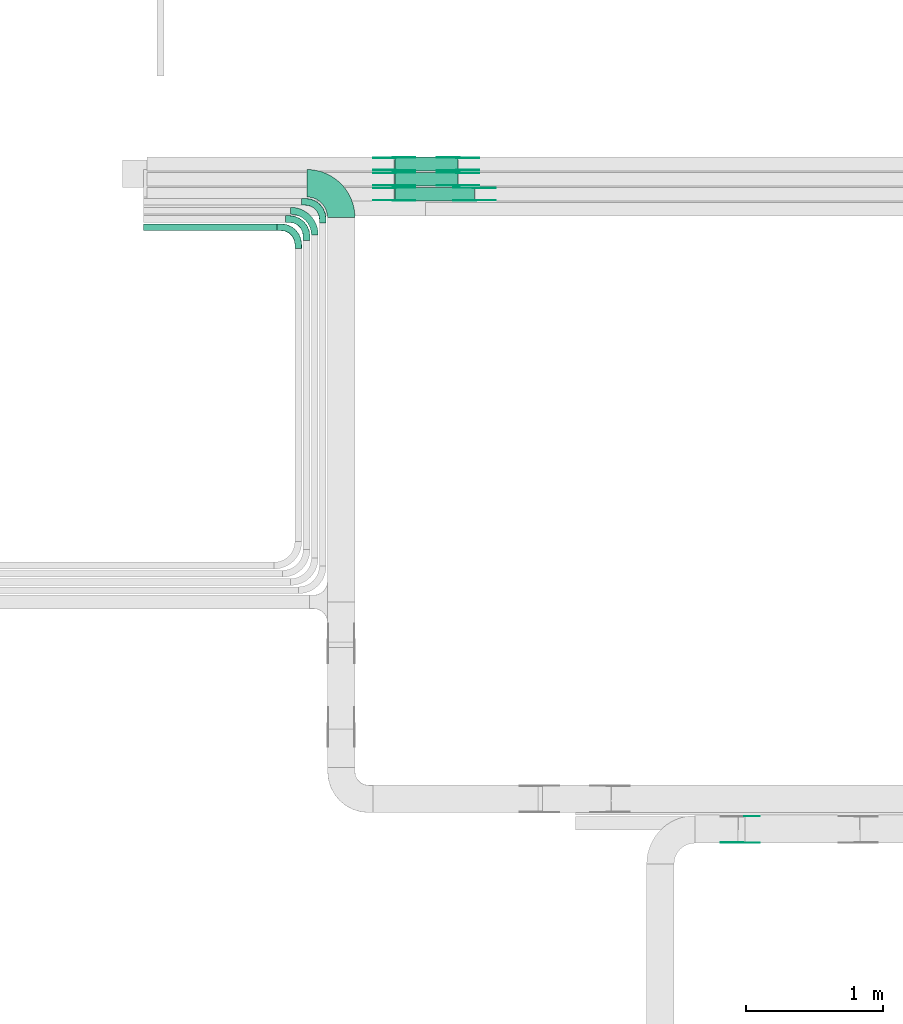
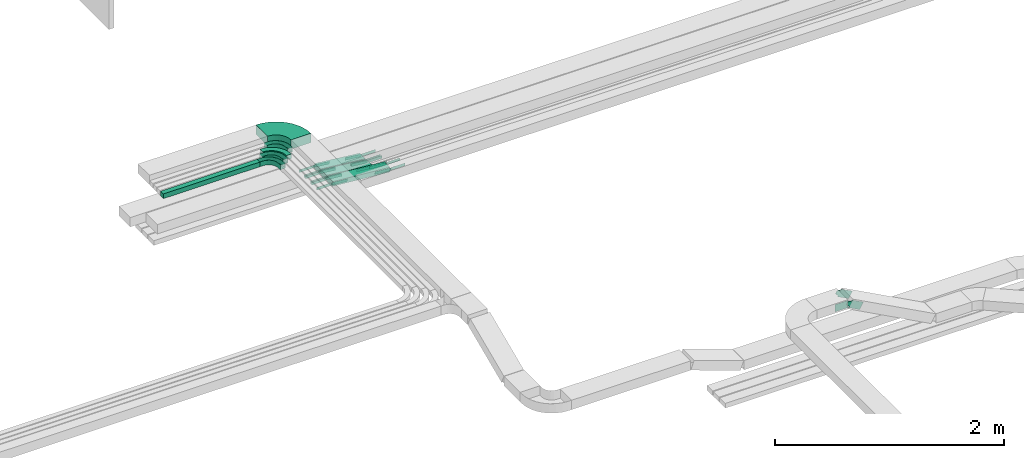
# One storey, part 4 of 25: 32 flow fittings, 4 flow segments.
"""IFC2X3 building model written with IfcOpenShell, lengths in millimetres."""

from ifc_helpers import new_model, entity, si_unit, converted_unit, derived_unit, direction, frame, frame_2d, origin, place, context, subcontext, project, spatial, polyline, circle_curve, parameter, trimmed, segment, composite_curve, rectangle, outline, extrude, faceted_brep, source, transform, mapped, material, type_object, type_shapes, element, save


model = new_model("IFC2X3")

# Units and contexts
model_context = context("Model", 3, precision=0.01, world=origin(), true_north=direction((6.12303176911189e-17, 1.0)))
body_context = subcontext(model_context, "Body", "Model", "MODEL_VIEW")
ifc_project = project(units=[si_unit("LENGTHUNIT", "METRE", prefix="MILLI"), si_unit("AREAUNIT", "SQUARE_METRE"), si_unit("VOLUMEUNIT", "CUBIC_METRE"), converted_unit("PLANEANGLEUNIT", "DEGREE", entity("IfcRatioMeasure", 0.0174532925199433), si_unit("PLANEANGLEUNIT", "RADIAN"), dimensions=[0, 0, 0, 0, 0, 0, 0]), si_unit("MASSUNIT", "GRAM", prefix="KILO"), derived_unit("MASSDENSITYUNIT", [(si_unit("MASSUNIT", "GRAM", prefix="KILO"), 1), (si_unit("LENGTHUNIT", "METRE"), -3)]), derived_unit("MOMENTOFINERTIAUNIT", [(si_unit("LENGTHUNIT", "METRE"), 4)]), si_unit("TIMEUNIT", "SECOND"), si_unit("FREQUENCYUNIT", "HERTZ"), si_unit("THERMODYNAMICTEMPERATUREUNIT", "DEGREE_CELSIUS"), derived_unit("THERMALTRANSMITTANCEUNIT", [(si_unit("MASSUNIT", "GRAM", prefix="KILO"), 1), (si_unit("THERMODYNAMICTEMPERATUREUNIT", "KELVIN"), -1), (si_unit("TIMEUNIT", "SECOND"), -3)]), derived_unit("VOLUMETRICFLOWRATEUNIT", [(si_unit("LENGTHUNIT", "METRE"), 3), (si_unit("TIMEUNIT", "SECOND"), -1)]), derived_unit("MASSFLOWRATEUNIT", [(si_unit("MASSUNIT", "GRAM", prefix="KILO"), 1), (si_unit("TIMEUNIT", "SECOND"), -1)]), derived_unit("ROTATIONALFREQUENCYUNIT", [(si_unit("TIMEUNIT", "SECOND"), -1)]), si_unit("ELECTRICCURRENTUNIT", "AMPERE"), si_unit("ELECTRICVOLTAGEUNIT", "VOLT"), si_unit("POWERUNIT", "WATT"), si_unit("FORCEUNIT", "NEWTON", prefix="KILO"), si_unit("ILLUMINANCEUNIT", "LUX"), si_unit("LUMINOUSFLUXUNIT", "LUMEN"), si_unit("LUMINOUSINTENSITYUNIT", "CANDELA"), derived_unit("USERDEFINED", [(si_unit("MASSUNIT", "GRAM", prefix="KILO"), -1), (si_unit("LENGTHUNIT", "METRE"), -2), (si_unit("TIMEUNIT", "SECOND"), 3), (si_unit("LUMINOUSFLUXUNIT", "LUMEN"), 1)]), derived_unit("LINEARVELOCITYUNIT", [(si_unit("LENGTHUNIT", "METRE"), 1), (si_unit("TIMEUNIT", "SECOND"), -1)]), si_unit("PRESSUREUNIT", "PASCAL"), derived_unit("USERDEFINED", [(si_unit("LENGTHUNIT", "METRE"), -2), (si_unit("MASSUNIT", "GRAM", prefix="KILO"), 1), (si_unit("TIMEUNIT", "SECOND"), -2)]), derived_unit("LINEARFORCEUNIT", [(si_unit("MASSUNIT", "GRAM", prefix="KILO"), 1), (si_unit("LENGTHUNIT", "METRE"), 1), (si_unit("TIMEUNIT", "SECOND"), -2), (si_unit("LENGTHUNIT", "METRE"), -1)]), derived_unit("PLANARFORCEUNIT", [(si_unit("MASSUNIT", "GRAM", prefix="KILO"), 1), (si_unit("LENGTHUNIT", "METRE"), 1), (si_unit("TIMEUNIT", "SECOND"), -2), (si_unit("LENGTHUNIT", "METRE"), -2)])], contexts=[model_context])

# Site, building, storey
site_placement = place(None, frame((0.0, -0.00077364408347762, 0.0)))
site = spatial("IfcSite", under=ifc_project, at=site_placement, CompositionType="ELEMENT")
building_placement = place(site_placement, origin())
building = spatial("IfcBuilding", under=site, at=building_placement, CompositionType="ELEMENT")
storey_placement = place(building_placement, frame((0.0, 0.0, 24000.0)))
storey = spatial("IfcBuildingStorey", under=building, at=storey_placement, CompositionType="ELEMENT", Elevation=24000.0)

# Flow segments
cable_carrier_segment_type = type_object("IfcCableCarrierSegmentType", PredefinedType="CABLETRAYSEGMENT")
flow_segment_1_placement = place(storey_placement, frame((16371.7335612672, 14262.4130642905, 3340.0)))
element("IfcFlowSegment", 1, at=flow_segment_1_placement, inside=storey, type_object=cable_carrier_segment_type, context=body_context, shape_type="SweptSolid", body=[
    extrude(rectangle(XDim=973.920225446046, YDim=50.0000000000016, at=frame_2d((-1.10844666778576e-12, 1.08357767203415e-12), x_axis=(1.0, 0.0))), frame((486.960112723024, 25.0, 0.0)), (0.0, 0.0, 1.0), 49.9999999999973),
])
flow_segment_2_placement = place(storey_placement, frame((18199.2656967331, 14697.8235638227, 2650.41845273249)))
element("IfcFlowSegment", 2, at=flow_segment_2_placement, inside=storey, type_object=cable_carrier_segment_type, context=body_context, shape_type="SweptSolid", body=[
    extrude(rectangle(XDim=49.9999999999976, YDim=99.9999999999989, at=frame_2d((0.0, 0.0), x_axis=(0.0, 1.0))), frame((2.68028021418136, 50.0, 74.3071878331849), z_axis=(0.994236268075928, 0.0, -0.10721120856726), x_axis=(0.0, 1.0, 0.0)), (0.0, 0.0, 1.0), 461.251037015058),
])
flow_segment_3_placement = place(storey_placement, frame((18199.2656967331, 14587.8235638227, 2650.41845273249)))
element("IfcFlowSegment", 3, at=flow_segment_3_placement, inside=storey, type_object=cable_carrier_segment_type, context=body_context, shape_type="SweptSolid", body=[
    extrude(rectangle(XDim=49.9999999999976, YDim=99.9999999999989, at=frame_2d((2.16715534406831e-12, 0.0), x_axis=(0.0, 1.0))), frame((2.68028021418136, 50.0, 74.3071878331849), z_axis=(0.994236268075928, 0.0, -0.10721120856726), x_axis=(0.0, 1.0, 0.0)), (0.0, 0.0, 1.0), 461.251037015058),
])
flow_segment_4_placement = place(storey_placement, frame((18199.4995784391, 14477.8235638227, 2650.28239783158)))
element("IfcFlowSegment", 4, at=flow_segment_4_placement, inside=storey, type_object=cable_carrier_segment_type, context=body_context, shape_type="SweptSolid", body=[
    extrude(rectangle(XDim=49.9999999999984, YDim=99.9999999999989, at=frame_2d((0.0, 0.0), x_axis=(0.0, 1.0))), frame((2.13376564128524, 50.0, 74.5264298951981), z_axis=(0.996350977668468, 0.0, -0.0853506256514122), x_axis=(0.0, 1.0, 0.0)), (0.0, 0.0, 1.0), 581.339094760914),
])

# Flow fittings
ifc_material_1 = material(Name="G")
cable_carrier_fitting_type_1 = type_object("IfcCableCarrierFittingType", PredefinedType="NOTDEFINED", material=ifc_material_1)
shared_shape_1 = source(origin(), body_context, "Body", "SweptSolid", [
    extrude(outline(composite_curve([segment(trimmed(circle_curve(frame_2d((-44.5901162790698, 0.0), x_axis=(1.0, 0.0)), 12.5), [parameter(90.0000000000007)], [parameter(270.0)], True, "PARAMETER"), True, "CONTINUOUS"), segment(polyline([(-44.5901162790697, -12.5), (-33.0901162790698, -12.5)]), True, "CONTINUOUS"), segment(polyline([(-33.0901162790698, -12.5), (-31.2296511627907, -14.5)]), True, "CONTINUOUS"), segment(polyline([(-31.2296511627907, -14.5), (108.90988372093, -14.5)]), True, "CONTINUOUS"), segment(polyline([(108.90988372093, -14.5), (108.90988372093, 14.5)]), True, "CONTINUOUS"), segment(polyline([(108.90988372093, 14.5), (-31.2296511627907, 14.5)]), True, "CONTINUOUS"), segment(polyline([(-31.2296511627907, 14.5), (-33.0901162790698, 12.5)]), True, "CONTINUOUS"), segment(polyline([(-33.0901162790698, 12.5), (-44.5901162790699, 12.5)]), True, "CONTINUOUS")], self_intersect=False)), frame((44.5901162790698, 0.0, 0.0), z_axis=(0.0, 0.0, -1.0), x_axis=(1.0, 0.0, 0.0)), (0.0, 0.0, -1.0), 2.0),
])
type_shapes(cable_carrier_fitting_type_1, [shared_shape_1])
for number, where, z_axis, x_axis in (
    (5, (18199.4016711439, 14793.2835638329, 2725.0), (0.0, 1.0, 0.0), (0.994236268075924, 0.0, -0.107211208567296)),
    (6, (18663.0827924385, 14793.2835638329, 2675.0), (0.0, 1.0, 0.0), (-0.994236268075924, 0.0, 0.107211208567296)),
    (7, (18199.4016711439, 14683.2835638329, 2725.0), (0.0, 1.0, 0.0), (0.994236268075924, 0.0, -0.107211208567296)),
    (8, (18663.0827924385, 14683.2835638329, 2675.0), (0.0, 1.0, 0.0), (-0.994236268075924, 0.0, 0.107211208567296)),
    (9, (18199.4016711439, 14573.2835638329, 2725.0), (0.0, 1.0, 0.0), (0.996350977668465, 0.0, -0.0853506256514489)),
    (10, (18783.0827924387, 14573.2835638329, 2675.0), (0.0, 1.0, 0.0), (-0.996350977668465, 0.0, 0.0853506256514489)),
):
    element("IfcFlowFitting", number, at=place(storey_placement, frame(where, z_axis=z_axis, x_axis=x_axis)), inside=storey, type_object=cable_carrier_fitting_type_1, material=ifc_material_1, context=body_context, shape_type="MappedRepresentation", body=[
        mapped(shared_shape_1, transform((0.0, 0.0, 0.0), scale=1.0)),
    ])
cable_carrier_fitting_type_2 = type_object("IfcCableCarrierFittingType", PredefinedType="NOTDEFINED", material=ifc_material_1)
shared_shape_2 = source(origin(), body_context, "Body", "SweptSolid", [
    extrude(outline(composite_curve([segment(trimmed(circle_curve(frame_2d((-44.5901162790697, 0.0), x_axis=(1.0, 0.0)), 12.5), [parameter(90.0000000000007)], [parameter(270.0)], True, "PARAMETER"), True, "CONTINUOUS"), segment(polyline([(-44.5901162790697, -12.5), (-33.0901162790697, -12.5)]), True, "CONTINUOUS"), segment(polyline([(-33.0901162790697, -12.5), (-31.2296511627907, -14.5)]), True, "CONTINUOUS"), segment(polyline([(-31.2296511627907, -14.5), (108.90988372093, -14.5)]), True, "CONTINUOUS"), segment(polyline([(108.90988372093, -14.5), (108.90988372093, 14.5)]), True, "CONTINUOUS"), segment(polyline([(108.90988372093, 14.5), (-31.2296511627907, 14.5)]), True, "CONTINUOUS"), segment(polyline([(-31.2296511627907, 14.5), (-33.0901162790698, 12.5)]), True, "CONTINUOUS"), segment(polyline([(-33.0901162790698, 12.5), (-44.5901162790699, 12.5)]), True, "CONTINUOUS")], self_intersect=False)), frame((44.5901162790697, 0.0, 0.0)), (0.0, 0.0, 1.0), 2.0),
])
type_shapes(cable_carrier_fitting_type_2, [shared_shape_2])
for number, where, z_axis, x_axis in (
    (11, (18199.4016711439, 14702.3635638126, 2725.0), (0.0, -1.0, 0.0), (0.994236268075924, 0.0, -0.107211208567296)),
    (12, (18663.0827924385, 14702.3635638126, 2675.0), (0.0, -1.0, 0.0), (-0.994236268075924, 0.0, 0.107211208567296)),
    (13, (18199.4016711439, 14592.3635638126, 2725.0), (0.0, -1.0, 0.0), (0.994236268075924, 0.0, -0.107211208567296)),
    (14, (18663.0827924385, 14592.3635638126, 2675.0), (0.0, -1.0, 0.0), (-0.994236268075924, 0.0, 0.107211208567296)),
    (15, (18199.4016711439, 14482.3635638126, 2725.0), (0.0, -1.0, 0.0), (0.996350977668465, 0.0, -0.0853506256514489)),
    (16, (18783.0827924387, 14482.3635638126, 2675.0), (0.0, -1.0, 0.0), (-0.996350977668465, 0.0, 0.0853506256514489)),
):
    element("IfcFlowFitting", number, at=place(storey_placement, frame(where, z_axis=z_axis, x_axis=x_axis)), inside=storey, type_object=cable_carrier_fitting_type_2, material=ifc_material_1, context=body_context, shape_type="MappedRepresentation", body=[
        mapped(shared_shape_2, transform((0.0, 0.0, 0.0), scale=1.0)),
    ])
cable_carrier_fitting_type_3 = type_object("IfcCableCarrierFittingType", PredefinedType="NOTDEFINED", material=ifc_material_1)
shared_shape_3 = source(origin(), body_context, "Body", "SweptSolid", [
    extrude(outline(composite_curve([segment(trimmed(circle_curve(frame_2d((-44.5901162790698, 0.0), x_axis=(1.0, 0.0)), 12.5), [parameter(90.0000000000007)], [parameter(270.0)], True, "PARAMETER"), True, "CONTINUOUS"), segment(polyline([(-44.5901162790697, -12.5), (-33.0901162790698, -12.5)]), True, "CONTINUOUS"), segment(polyline([(-33.0901162790698, -12.5), (-31.2296511627907, -14.5)]), True, "CONTINUOUS"), segment(polyline([(-31.2296511627907, -14.5), (108.90988372093, -14.5)]), True, "CONTINUOUS"), segment(polyline([(108.90988372093, -14.5), (108.90988372093, 14.5)]), True, "CONTINUOUS"), segment(polyline([(108.90988372093, 14.5), (-31.2296511627907, 14.5)]), True, "CONTINUOUS"), segment(polyline([(-31.2296511627907, 14.5), (-33.0901162790698, 12.5)]), True, "CONTINUOUS"), segment(polyline([(-33.0901162790698, 12.5), (-44.5901162790699, 12.5)]), True, "CONTINUOUS")], self_intersect=False)), frame((44.5901162790698, 0.0, 0.0), z_axis=(0.0, 0.0, -1.0), x_axis=(1.0, 0.0, 0.0)), (0.0, 0.0, -1.0), 2.0),
])
type_shapes(cable_carrier_fitting_type_3, [shared_shape_3])
for number, where, z_axis, x_axis in (
    (17, (18199.401671144, 14704.3635638126, 2725.0), (0.0, -1.0, 0.0), (-1.0, 0.0, 0.0)),
    (18, (18663.0827924385, 14704.3635638126, 2675.0), (0.0, -1.0, 0.0), (1.0, 0.0, 0.0)),
    (19, (18199.401671144, 14594.3635638126, 2725.0), (0.0, -1.0, 0.0), (-1.0, 0.0, 0.0)),
    (20, (18663.0827924385, 14594.3635638126, 2675.0), (0.0, -1.0, 0.0), (1.0, 0.0, 0.0)),
    (21, (18199.401671144, 14484.3635638126, 2725.0), (0.0, -1.0, 0.0), (-1.0, 0.0, 0.0)),
    (22, (18783.0827924387, 14484.3635638126, 2675.0), (0.0, -1.0, 0.0), (1.0, 0.0, 0.0)),
):
    element("IfcFlowFitting", number, at=place(storey_placement, frame(where, z_axis=z_axis, x_axis=x_axis)), inside=storey, type_object=cable_carrier_fitting_type_3, material=ifc_material_1, context=body_context, shape_type="MappedRepresentation", body=[
        mapped(shared_shape_3, transform((0.0, 0.0, 0.0), scale=1.0)),
    ])
cable_carrier_fitting_type_4 = type_object("IfcCableCarrierFittingType", PredefinedType="NOTDEFINED", material=ifc_material_1)
shared_shape_4 = source(origin(), body_context, "Body", "SweptSolid", [
    extrude(outline(composite_curve([segment(trimmed(circle_curve(frame_2d((-44.5901162790697, 0.0), x_axis=(1.0, 0.0)), 12.5), [parameter(90.0000000000007)], [parameter(270.0)], True, "PARAMETER"), True, "CONTINUOUS"), segment(polyline([(-44.5901162790697, -12.5), (-33.0901162790697, -12.5)]), True, "CONTINUOUS"), segment(polyline([(-33.0901162790697, -12.5), (-31.2296511627907, -14.5)]), True, "CONTINUOUS"), segment(polyline([(-31.2296511627907, -14.5), (108.90988372093, -14.5)]), True, "CONTINUOUS"), segment(polyline([(108.90988372093, -14.5), (108.90988372093, 14.5)]), True, "CONTINUOUS"), segment(polyline([(108.90988372093, 14.5), (-31.2296511627907, 14.5)]), True, "CONTINUOUS"), segment(polyline([(-31.2296511627907, 14.5), (-33.0901162790698, 12.5)]), True, "CONTINUOUS"), segment(polyline([(-33.0901162790698, 12.5), (-44.5901162790699, 12.5)]), True, "CONTINUOUS")], self_intersect=False)), frame((44.5901162790697, 0.0, 0.0)), (0.0, 0.0, 1.0), 2.0),
])
type_shapes(cable_carrier_fitting_type_4, [shared_shape_4])
for number, where, z_axis, x_axis in (
    (23, (18199.401671144, 14791.2835638329, 2725.0), (0.0, 1.0, 0.0), (-1.0, 0.0, 0.0)),
    (24, (18663.0827924385, 14791.2835638329, 2675.0), (0.0, 1.0, 0.0), (1.0, 0.0, 0.0)),
    (25, (18199.401671144, 14681.2835638329, 2725.0), (0.0, 1.0, 0.0), (-1.0, 0.0, 0.0)),
    (26, (18663.0827924385, 14681.2835638329, 2675.0), (0.0, 1.0, 0.0), (1.0, 0.0, 0.0)),
    (27, (18199.401671144, 14571.2835638329, 2725.0), (0.0, 1.0, 0.0), (-1.0, 0.0, 0.0)),
    (28, (18783.0827924387, 14571.2835638329, 2675.0), (0.0, 1.0, 0.0), (1.0, 0.0, 0.0)),
):
    element("IfcFlowFitting", number, at=place(storey_placement, frame(where, z_axis=z_axis, x_axis=x_axis)), inside=storey, type_object=cable_carrier_fitting_type_4, material=ifc_material_1, context=body_context, shape_type="MappedRepresentation", body=[
        mapped(shared_shape_4, transform((0.0, 0.0, 0.0), scale=1.0)),
    ])
cable_carrier_fitting_type_5 = type_object("IfcCableCarrierFittingType", PredefinedType="NOTDEFINED", material=ifc_material_1)
shared_shape_5 = source(origin(), body_context, "Body", "SweptSolid", [
    extrude(outline(composite_curve([segment(trimmed(circle_curve(frame_2d((-41.4651162790697, 0.0), x_axis=(1.0, 0.0)), 25.0), [parameter(90.0000000000007)], [parameter(270.0)], True, "PARAMETER"), True, "CONTINUOUS"), segment(polyline([(-41.4651162790697, -25.0), (-29.9651162790697, -25.0)]), True, "CONTINUOUS"), segment(polyline([(-29.9651162790697, -25.0), (-28.1046511627907, -38.5)]), True, "CONTINUOUS"), segment(polyline([(-28.1046511627907, -38.5), (99.5348837209303, -38.5)]), True, "CONTINUOUS"), segment(polyline([(99.5348837209303, -38.5), (99.5348837209303, 38.5)]), True, "CONTINUOUS"), segment(polyline([(99.5348837209303, 38.5), (-28.1046511627907, 38.5)]), True, "CONTINUOUS"), segment(polyline([(-28.1046511627907, 38.5), (-29.9651162790697, 25.0)]), True, "CONTINUOUS"), segment(polyline([(-29.9651162790697, 25.0), (-41.46511627907, 25.0)]), True, "CONTINUOUS")], self_intersect=False)), frame((41.4651162790697, 0.0, 0.0), z_axis=(0.0, 0.0, -1.0), x_axis=(1.0, 0.0, 0.0)), (0.0, 0.0, -1.0), 2.0),
])
type_shapes(cable_carrier_fitting_type_5, [shared_shape_5])
flow_fitting_1_placement = place(storey_placement, frame((20716.8706665486, 9998.12488995506, 3401.74219071097), z_axis=(0.0, 1.0, 0.0), x_axis=(0.881037228424637, 0.0, -0.473046934383719)))
element("IfcFlowFitting", 29, at=flow_fitting_1_placement, inside=storey, type_object=cable_carrier_fitting_type_5, material=ifc_material_1, context=body_context, shape_type="MappedRepresentation", body=[
    mapped(shared_shape_5, transform((0.0, 0.0, 0.0), scale=1.0)),
])
cable_carrier_fitting_type_6 = type_object("IfcCableCarrierFittingType", PredefinedType="NOTDEFINED", material=ifc_material_1)
shared_shape_6 = source(origin(), body_context, "Body", "SweptSolid", [
    extrude(outline(composite_curve([segment(trimmed(circle_curve(frame_2d((-41.4651162790697, 0.0), x_axis=(1.0, 0.0)), 25.0), [parameter(90.0000000000007)], [parameter(270.0)], True, "PARAMETER"), True, "CONTINUOUS"), segment(polyline([(-41.4651162790697, -25.0), (-29.9651162790697, -25.0)]), True, "CONTINUOUS"), segment(polyline([(-29.9651162790697, -25.0), (-28.1046511627907, -38.5)]), True, "CONTINUOUS"), segment(polyline([(-28.1046511627907, -38.5), (99.5348837209303, -38.5)]), True, "CONTINUOUS"), segment(polyline([(99.5348837209303, -38.5), (99.5348837209303, 38.5)]), True, "CONTINUOUS"), segment(polyline([(99.5348837209303, 38.5), (-28.1046511627907, 38.5)]), True, "CONTINUOUS"), segment(polyline([(-28.1046511627907, 38.5), (-29.9651162790697, 25.0)]), True, "CONTINUOUS"), segment(polyline([(-29.9651162790697, 25.0), (-41.46511627907, 25.0)]), True, "CONTINUOUS")], self_intersect=False)), frame((41.4651162790697, 0.0, 0.0)), (0.0, 0.0, 1.0), 2.0),
])
type_shapes(cable_carrier_fitting_type_6, [shared_shape_6])
flow_fitting_2_placement = place(storey_placement, frame((20716.8706665486, 9807.20488993474, 3401.74219071097), z_axis=(0.0, -1.0, 0.0), x_axis=(0.881037228424637, 0.0, -0.473046934383719)))
element("IfcFlowFitting", 30, at=flow_fitting_2_placement, inside=storey, type_object=cable_carrier_fitting_type_6, material=ifc_material_1, context=body_context, shape_type="MappedRepresentation", body=[
    mapped(shared_shape_6, transform((0.0, 0.0, 0.0), scale=1.0)),
])
cable_carrier_fitting_type_7 = type_object("IfcCableCarrierFittingType", PredefinedType="NOTDEFINED", material=ifc_material_1)
shared_shape_7 = source(origin(), body_context, "Body", "SweptSolid", [
    extrude(outline(composite_curve([segment(trimmed(circle_curve(frame_2d((-41.4651162790697, 0.0), x_axis=(1.0, 0.0)), 25.0), [parameter(90.0000000000007)], [parameter(270.0)], True, "PARAMETER"), True, "CONTINUOUS"), segment(polyline([(-41.4651162790697, -25.0), (-29.9651162790697, -25.0)]), True, "CONTINUOUS"), segment(polyline([(-29.9651162790697, -25.0), (-28.1046511627907, -38.5)]), True, "CONTINUOUS"), segment(polyline([(-28.1046511627907, -38.5), (99.5348837209303, -38.5)]), True, "CONTINUOUS"), segment(polyline([(99.5348837209303, -38.5), (99.5348837209303, 38.5)]), True, "CONTINUOUS"), segment(polyline([(99.5348837209303, 38.5), (-28.1046511627907, 38.5)]), True, "CONTINUOUS"), segment(polyline([(-28.1046511627907, 38.5), (-29.9651162790697, 25.0)]), True, "CONTINUOUS"), segment(polyline([(-29.9651162790697, 25.0), (-41.46511627907, 25.0)]), True, "CONTINUOUS")], self_intersect=False)), frame((41.4651162790697, 0.0, 0.0), z_axis=(0.0, 0.0, -1.0), x_axis=(1.0, 0.0, 0.0)), (0.0, 0.0, -1.0), 2.0),
])
type_shapes(cable_carrier_fitting_type_7, [shared_shape_7])
flow_fitting_3_placement = place(storey_placement, frame((20716.8706665486, 9809.20488993474, 3401.74219071097), z_axis=(0.0, -1.0, 0.0), x_axis=(-1.0, 0.0, 0.0)))
element("IfcFlowFitting", 31, at=flow_fitting_3_placement, inside=storey, type_object=cable_carrier_fitting_type_7, material=ifc_material_1, context=body_context, shape_type="MappedRepresentation", body=[
    mapped(shared_shape_7, transform((0.0, 0.0, 0.0), scale=1.0)),
])
ifc_material_2 = material()
cable_carrier_fitting_type_8 = type_object("IfcCableCarrierFittingType", Name="470_DKC_S5_Variable Angle Elbow 0-45:-", PredefinedType="NOTDEFINED", material=ifc_material_2)
shared_shape_8 = source(origin(), body_context, "Body", "SweptSolid", [
    extrude(outline(composite_curve([segment(polyline([(-125.750000000001, -225.25), (-124.749999999999, -225.25)]), True, "CONTINUOUS"), segment(trimmed(circle_curve(frame_2d((-124.75, 124.75), x_axis=(0.0, -1.0)), 350.0), [parameter(0.0)], [parameter(90.0000000000001)], True, "PARAMETER"), True, "CONTINUOUS"), segment(polyline([(225.25, 124.75), (225.25, 125.749999999999)]), True, "CONTINUOUS"), segment(polyline([(225.25, 125.749999999999), (25.25, 125.750000000001)]), True, "CONTINUOUS"), segment(polyline([(25.25, 125.750000000001), (25.25, 124.75)]), True, "CONTINUOUS"), segment(trimmed(circle_curve(frame_2d((-124.75, 124.75), x_axis=(0.0, -1.0)), 150.0), [parameter(0.0)], [parameter(90.0000000000001)], True, "PARAMETER"), False, "CONTINUOUS"), segment(polyline([(-124.749999999999, -25.2500000000003), (-125.750000000001, -25.2500000000003)]), True, "CONTINUOUS"), segment(polyline([(-125.750000000001, -25.2500000000003), (-125.750000000001, -225.25)]), True, "CONTINUOUS")], self_intersect=False)), frame((-125.249999999991, 125.249999999992, -50.0)), (0.0, 0.0, 1.0), 100.0),
])
type_shapes(cable_carrier_fitting_type_8, [shared_shape_8])
flow_fitting_4_placement = place(storey_placement, frame((17813.1522790167, 14607.7421886283, 3390.0), z_axis=(0.0, 0.0, 1.0), x_axis=(0.0, 1.0, 0.0)))
element("IfcFlowFitting", 32, at=flow_fitting_4_placement, inside=storey, type_object=cable_carrier_fitting_type_8, material=ifc_material_2, Name="470_DKC_S5_Variable Angle Elbow 0-45:-", ObjectType="470_DKC_S5_Variable Angle Elbow 0-45:-", context=body_context, shape_type="MappedRepresentation", body=[
    mapped(shared_shape_8, transform((0.0, 0.0, 0.0), scale=1.0)),
])
cable_carrier_fitting_type_9 = type_object("IfcCableCarrierFittingType", Name="470_DKC_S5_Variable Angle Elbow 0-45:-", PredefinedType="NOTDEFINED", material=ifc_material_2)
shared_shape_9 = source(origin(), body_context, "Body", "SweptSolid", [
    extrude(outline(composite_curve([segment(polyline([(-88.2500000000001, -112.75), (-87.2499999999989, -112.75)]), True, "CONTINUOUS"), segment(trimmed(circle_curve(frame_2d((-87.2500000000001, 87.2499999999992), x_axis=(0.0, -1.0)), 200.0), [parameter(0.0)], [parameter(90.0000000000001)], True, "PARAMETER"), True, "CONTINUOUS"), segment(polyline([(112.75, 87.2500000000004), (112.75, 88.2500000000002)]), True, "CONTINUOUS"), segment(polyline([(112.75, 88.2500000000002), (62.7499999999997, 88.2500000000005)]), True, "CONTINUOUS"), segment(polyline([(62.7499999999997, 88.2500000000005), (62.7499999999997, 87.2500000000001)]), True, "CONTINUOUS"), segment(trimmed(circle_curve(frame_2d((-87.2500000000001, 87.2499999999992), x_axis=(0.0, -1.0)), 150.0), [parameter(0.0)], [parameter(90.0000000000001)], True, "PARAMETER"), False, "CONTINUOUS"), segment(polyline([(-87.2499999999991, -62.7500000000006), (-88.2500000000003, -62.7500000000006)]), True, "CONTINUOUS"), segment(polyline([(-88.2500000000003, -62.7500000000006), (-88.2500000000001, -112.75)]), True, "CONTINUOUS")], self_intersect=False)), frame((-87.7499999999907, 87.749999999992, -25.0)), (0.0, 0.0, 1.0), 50.0000000000007),
])
type_shapes(cable_carrier_fitting_type_9, [shared_shape_9])
flow_fitting_5_placement = place(storey_placement, frame((17620.6537867132, 14407.4130642905, 3365.0), z_axis=(0.0, 0.0, 1.0), x_axis=(0.0, 1.0, 0.0)))
element("IfcFlowFitting", 33, at=flow_fitting_5_placement, inside=storey, type_object=cable_carrier_fitting_type_9, material=ifc_material_2, Name="470_DKC_S5_Variable Angle Elbow 0-45:-", ObjectType="470_DKC_S5_Variable Angle Elbow 0-45:-", context=body_context, shape_type="MappedRepresentation", body=[
    mapped(shared_shape_9, transform((0.0, 0.0, 0.0), scale=1.0)),
])
cable_carrier_fitting_type_10 = type_object("IfcCableCarrierFittingType", Name="470_DKC_S5_CPO 45 horizontal angle:-", PredefinedType="NOTDEFINED", material=ifc_material_2)
shared_shape_10 = source(origin(), body_context, "Body", "Brep", [
    faceted_brep([(-155.0, -24.2000000000082, -24.2000000000019), (-155.0, 24.1999999999917, -24.2000000000019), (-155.0, 24.1999999999917, 25.0), (-155.0, 25.0, 25.0), (-155.0, 25.0, -25.0), (-155.0, -25.0, -25.0), (-155.0, -25.0, 25.0), (-155.0, -24.2000000000082, 25.0), (-125.0, -25.0, -25.0), (-125.0, -25.0, 25.0), (-86.1771432346131, -19.8888739433687, 25.0), (-50.0, -4.90381056767425, 25.0), (-18.9339828220092, 18.9339828220094, 25.0), (4.90381056767451, 50.0, 25.0), (19.888873943369, 86.1771432346133, 25.0), (25.0, 125.0, 25.0), (25.0, 155.0, 25.0), (24.2000000000086, 155.0, 25.0), (24.2000000000086, 125.0, 25.0), (19.1161332823376, 86.3841984706954, 25.0), (4.2109902446468, 50.3999999999916, 25.0), (-19.4996682469585, 19.4996682469588, 25.0), (-50.3999999999914, -4.21099024464653, 25.0), (-86.3841984706952, -19.1161332823372, 25.0), (-125.0, -24.2000000000082, 25.0), (-125.0, 24.1999999999917, 25.0), (-93.8510869669966, 29.1335031574402, 25.0), (-65.75124656891, 43.451086966997, 25.0), (-43.4510869669967, 65.7512465689103, 25.0), (-29.1335031574399, 93.8510869669968, 25.0), (-24.1999999999914, 125.0, 25.0), (-24.1999999999913, 155.0, 25.0), (-25.0, 155.0, 25.0), (-25.0, 125.0, 25.0), (-29.8943483704759, 94.0983005624967, 25.0), (-44.0983005624965, 66.2214747707442, 25.0), (-66.2214747707439, 44.0983005624968, 25.0), (-94.0983005624965, 29.8943483704762, 25.0), (-125.0, 25.0, 25.0), (-125.0, -24.2000000000082, -24.2000000000019), (-86.3841984706952, -19.1161332823372, -24.2000000000019), (-50.3999999999914, -4.21099024464653, -24.2000000000019), (-19.4996682469585, 19.4996682469588, -24.2000000000019), (4.2109902446468, 50.3999999999916, -24.2000000000019), (19.1161332823376, 86.3841984706954, -24.2000000000019), (24.2000000000086, 125.0, -24.2000000000019), (24.2000000000086, 155.0, -24.2000000000019), (-24.1999999999913, 155.0, -24.2000000000019), (-24.1999999999914, 125.0, -24.2000000000019), (-29.1335031574399, 93.8510869669968, -24.2000000000019), (-43.4510869669967, 65.7512465689103, -24.2000000000019), (-65.75124656891, 43.451086966997, -24.2000000000019), (-93.8510869669966, 29.1335031574402, -24.2000000000019), (-125.0, 24.1999999999917, -24.2000000000019), (-125.0, 25.0, -25.0), (-94.0983005624965, 29.8943483704762, -25.0), (-66.2214747707439, 44.0983005624968, -25.0), (-44.0983005624965, 66.2214747707442, -25.0), (-29.8943483704759, 94.0983005624967, -25.0), (-25.0, 125.0, -25.0), (-25.0, 155.0, -25.0), (25.0, 155.0, -25.0), (25.0, 125.0, -25.0), (19.888873943369, 86.1771432346133, -25.0), (4.90381056767451, 50.0, -25.0), (-18.9339828220092, 18.9339828220094, -25.0), (-50.0, -4.90381056767425, -25.0), (-86.1771432346131, -19.8888739433687, -25.0)], [[[0, 1, 2, 3, 4, 5, 6, 7]], [[6, 5, 8, 9]], [[7, 6, 9, 10, 11, 12, 13, 14, 15, 16, 17, 18, 19, 20, 21, 22, 23, 24]], [[3, 2, 25, 26, 27, 28, 29, 30, 31, 32, 33, 34, 35, 36, 37, 38]], [[0, 7, 24, 39]], [[1, 0, 39, 40, 41, 42, 43, 44, 45, 46, 47, 48, 49, 50, 51, 52, 53]], [[2, 1, 53, 25]], [[4, 3, 38, 54]], [[4, 54, 55, 56, 57, 58, 59, 60, 61, 62, 63, 64, 65, 66, 67, 8, 5]], [[10, 9, 8, 67]], [[11, 10, 67, 66]], [[12, 11, 66, 65]], [[63, 62, 15, 14]], [[13, 64, 63, 14]], [[64, 13, 12, 65]], [[40, 39, 24, 23]], [[41, 40, 23, 22]], [[41, 22, 21, 42]], [[19, 18, 45, 44]], [[19, 44, 43, 20]], [[42, 21, 20, 43]], [[26, 25, 53, 52]], [[27, 26, 52, 51]], [[51, 50, 28, 27]], [[29, 28, 50, 49]], [[29, 49, 48, 30]], [[55, 54, 38, 37]], [[56, 55, 37, 36]], [[36, 35, 57, 56]], [[58, 57, 35, 34]], [[59, 58, 34, 33]], [[60, 32, 31, 47, 46, 17, 16, 61]], [[15, 62, 61, 16]], [[45, 18, 17, 46]], [[30, 48, 47, 31]], [[59, 33, 32, 60]]]),
])
type_shapes(cable_carrier_fitting_type_10, [shared_shape_10])
for number, where, z_axis, x_axis, name in (
    (34, (17500.6537867132, 14287.4130642905, 3365.0), (0.0, 0.0, 1.0), (0.0, 1.0, 0.0), "470_DKC_S5_45 horizontal angle"),
    (35, (17560.6537867132, 14347.4130642905, 3365.0), (0.0, 0.0, 1.0), (0.0, 1.0, 0.0), "470_DKC_S5_45 horizontal angle"),
    (36, (17678.1522790167, 14472.7421886283, 3365.0), (0.0, 0.0, 1.0), (0.0, 1.0, 0.0), "470_DKC_S5_45 horizontal angle"),
):
    element("IfcFlowFitting", number, at=place(storey_placement, frame(where, z_axis=z_axis, x_axis=x_axis)), inside=storey, type_object=cable_carrier_fitting_type_10, material=ifc_material_2, Name=name, ObjectType="470_DKC_S5_CPO 45 horizontal angle:-", context=body_context, shape_type="MappedRepresentation", body=[
        mapped(shared_shape_10, transform((0.0, 0.0, 0.0), scale=1.0)),
    ])

save(model, "model.ifc")
